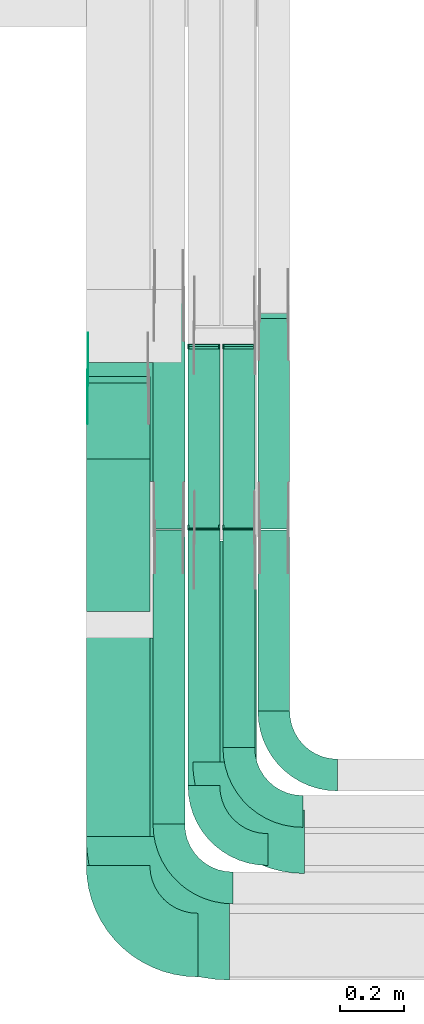
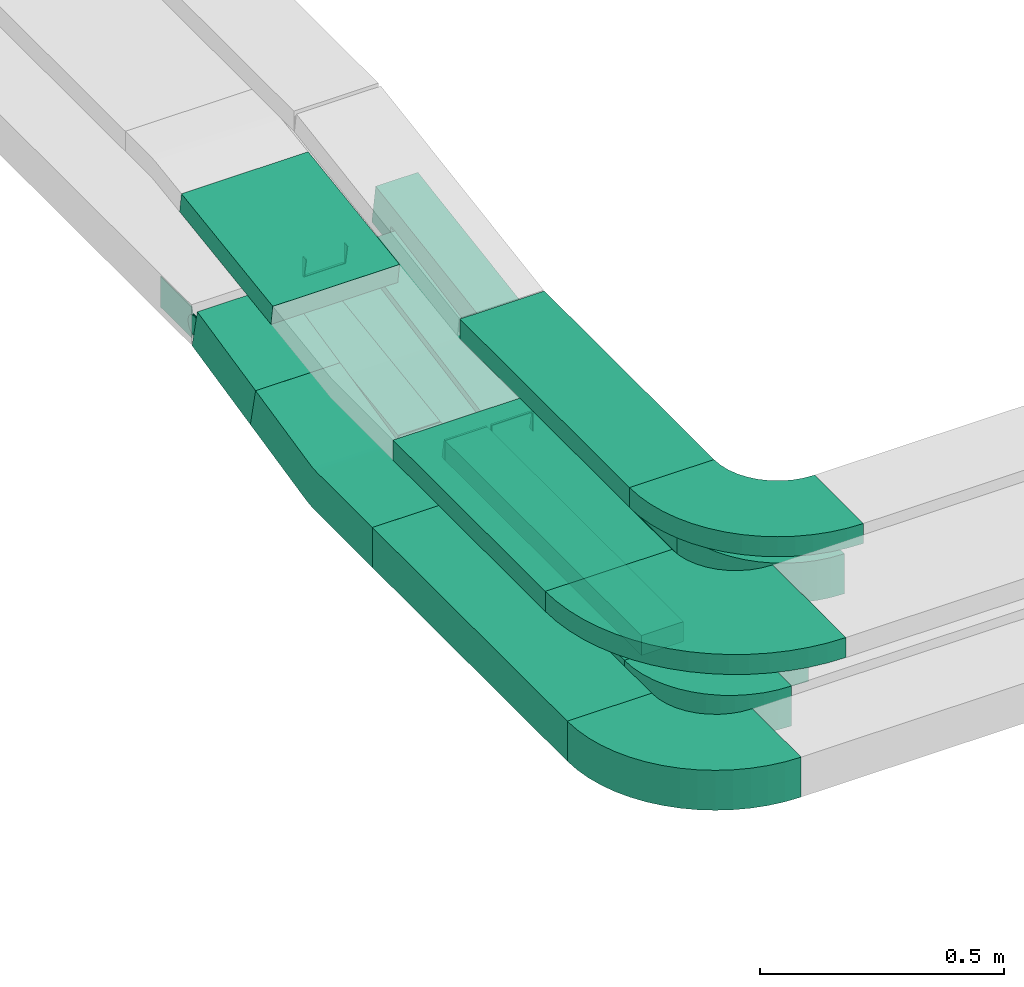
# One storey, part 4 of 31: 14 flow fittings, 13 flow segments.
"""IFC2X3 building model written with IfcOpenShell, lengths in millimetres."""

import ifcopenshell
import ifcopenshell.guid

model = None  # the IFC model being written
_history = None  # IfcOwnerHistory: only IFC2X3 demands one
_inside = {}  # id of a spatial element -> (the spatial element, [elements in it])
_under = {}  # id of a project, library or spatial element -> (it, [spatial elements below it])
_declared = {}  # id of a project -> (the project, [libraries it declares])
_typed = {}  # id of a type object -> (the type object, [elements of that type])
_made_of = {}  # id of a material, layer set ... -> (it, [elements and type objects made of it])


def new_model(schema):
    """Start an empty IFC model of exactly this schema.

    Asked for "IFC4X3", IfcOpenShell would pick the latest addendum, in which some entities
    have other attributes; the version numbers below select the first issue.
    IFC2X3 requires an IfcOwnerHistory on every rooted entity: one is made here for all.
    """
    global model, _history
    if schema == "IFC4X3":
        model = ifcopenshell.file(schema_version=(4, 3, 0, 0))
    else:
        model = ifcopenshell.file(schema=schema)
    _inside.clear()
    _under.clear()
    _declared.clear()
    _typed.clear()
    _made_of.clear()
    _history = None
    if model.schema == "IFC2X3":
        org = make("IfcOrganization", Name="unknown")
        user = make(
            "IfcPersonAndOrganization",
            ThePerson=make("IfcPerson", FamilyName="unknown"),
            TheOrganization=org,
        )
        app = make(
            "IfcApplication",
            ApplicationDeveloper=org,
            Version="unknown",
            ApplicationFullName="unknown",
            ApplicationIdentifier="unknown",
        )
        _history = make(
            "IfcOwnerHistory",
            OwningUser=user,
            OwningApplication=app,
            ChangeAction="ADDED",
            CreationDate=0,
        )
    return model


def make(cls, **values):
    """One entity of the class cls with the attributes given. An attribute that is None is left unset."""
    return model.create_entity(
        cls, **{name: value for name, value in values.items() if value is not None}
    )


def entity(cls, *values):
    """Any entity or typed value of the class cls, its attributes in the order of the schema. None: left unset."""
    e = model.create_entity(cls)
    for i, value in enumerate(values):
        if value is not None:
            e[i] = value
    return e


def rooted(cls, **values):
    """An entity with a GlobalId (a new one), such as an element, a storey or a relation."""
    return make(cls, GlobalId=ifcopenshell.guid.new(), OwnerHistory=_history, **values)


def si_unit(unit_type, name, prefix=None):
    """IfcSIUnit, for example si_unit("LENGTHUNIT", "METRE", prefix="MILLI")."""
    return make("IfcSIUnit", UnitType=unit_type, Prefix=prefix, Name=name)


def converted_unit(unit_type, name, factor, base, dimensions=None, offset=None):
    """IfcConversionBasedUnit, such as the inch: factor (a typed value) times the base unit."""
    return make(
        "IfcConversionBasedUnit"
        if offset is None
        else "IfcConversionBasedUnitWithOffset",
        ConversionOffset=offset,
        Dimensions=None
        if dimensions is None
        else entity("IfcDimensionalExponents", *dimensions),
        UnitType=unit_type,
        Name=name,
        ConversionFactor=make(
            "IfcMeasureWithUnit", ValueComponent=factor, UnitComponent=base
        ),
    )


def derived_unit(unit_type, elements):
    """IfcDerivedUnit: a product of units, each with its exponent."""
    return make(
        "IfcDerivedUnit",
        Elements=[
            make("IfcDerivedUnitElement", Unit=unit, Exponent=power)
            for unit, power in elements
        ],
        UnitType=unit_type,
    )


def assignment(units):
    """IfcUnitAssignment: the units of a project."""
    return None if units is None else make("IfcUnitAssignment", Units=units)


def point(xyz):
    """IfcCartesianPoint."""
    return None if xyz is None else make("IfcCartesianPoint", Coordinates=xyz)


def direction(xyz):
    """IfcDirection."""
    return None if xyz is None else make("IfcDirection", DirectionRatios=xyz)


def frame(location, z_axis=None, x_axis=None):
    """IfcAxis2Placement3D, a coordinate frame: its origin and axes. An axis left out is left unset."""
    return make(
        "IfcAxis2Placement3D",
        Location=point(location),
        Axis=direction(z_axis),
        RefDirection=direction(x_axis),
    )


def frame_2d(location, x_axis=None):
    """IfcAxis2Placement2D, a coordinate frame in the plane: its origin and x axis."""
    return make(
        "IfcAxis2Placement2D", Location=point(location), RefDirection=direction(x_axis)
    )


def origin():
    """The frame at (0, 0, 0) with its axes left unset."""
    return frame((0.0, 0.0, 0.0))


def origin_2d_with_axis():
    """The frame at (0, 0) in the plane with the x axis (1, 0) written out."""
    return frame_2d((0.0, 0.0), x_axis=(1.0, 0.0))


def place(relative_to, where):
    """IfcLocalPlacement: puts the frame where relative to a parent placement (None: the world)."""
    return make(
        "IfcLocalPlacement", PlacementRelTo=relative_to, RelativePlacement=where
    )


def context(
    kind, dimensions, precision=None, world=None, true_north=None, identifier=None
):
    """IfcGeometricRepresentationContext, for example the 3D "Model" context."""
    return make(
        "IfcGeometricRepresentationContext",
        ContextIdentifier=identifier,
        ContextType=kind,
        CoordinateSpaceDimension=dimensions,
        Precision=precision,
        WorldCoordinateSystem=world,
        TrueNorth=true_north,
    )


def subcontext(parent, identifier, kind, view, scale=None):
    """IfcGeometricRepresentationSubContext, for example "Body" below "Model"."""
    return make(
        "IfcGeometricRepresentationSubContext",
        ContextIdentifier=identifier,
        ContextType=kind,
        ParentContext=parent,
        TargetScale=scale,
        TargetView=view,
    )


def project(units=None, contexts=None):
    """IfcProject with its units and contexts."""
    return rooted(
        "IfcProject",
        Name="project",
        RepresentationContexts=contexts,
        UnitsInContext=assignment(units),
    )


def spatial(cls, under=None, at=None, **own):
    """A site, building, storey or space (cls), placed at a placement, below another one or the project."""
    s = rooted(cls, ObjectPlacement=at, **own)
    if under is not None:
        _under.setdefault(under.id(), (under, []))[1].append(s)
    return s


def polyline(points):
    """IfcPolyline through the points."""
    return make("IfcPolyline", Points=[point(p) for p in points])


def circle_curve(where, radius):
    """IfcCircle in the frame where."""
    return make("IfcCircle", Position=where, Radius=radius)


def parameter(value):
    """IfcParameterValue: where a trimmed curve begins or ends, as a parameter of its basis curve."""
    return model.create_entity("IfcParameterValue", value)


def trimmed(basis, trim1, trim2, sense, master):
    """IfcTrimmedCurve: the piece of a basis curve between two trims."""
    return make(
        "IfcTrimmedCurve",
        BasisCurve=basis,
        Trim1=trim1,
        Trim2=trim2,
        SenseAgreement=sense,
        MasterRepresentation=master,
    )


def segment(curve, same_sense, transition):
    """IfcCompositeCurveSegment."""
    return make(
        "IfcCompositeCurveSegment",
        Transition=transition,
        SameSense=same_sense,
        ParentCurve=curve,
    )


def composite_curve(segments, self_intersect=None):
    """IfcCompositeCurve: segments joined end to end."""
    return make("IfcCompositeCurve", Segments=segments, SelfIntersect=self_intersect)


def profile(cls, at=None, kind="AREA", **sizes):
    """A parametric profile (cls). Its sizes go by their IFC names, for example OverallWidth=200.0."""
    return make(cls, ProfileType=kind, Position=at, **sizes)


def rectangle(**sizes):
    """IfcRectangleProfileDef."""
    return profile("IfcRectangleProfileDef", **sizes)


def outline(outer, holes=None, kind="AREA"):
    """IfcArbitraryClosedProfileDef: a profile drawn as a closed curve; with holes, ...WithVoids."""
    if holes is None:
        return make("IfcArbitraryClosedProfileDef", ProfileType=kind, OuterCurve=outer)
    return make(
        "IfcArbitraryProfileDefWithVoids",
        ProfileType=kind,
        OuterCurve=outer,
        InnerCurves=holes,
    )


def extrude(swept, where, along, depth):
    """IfcExtrudedAreaSolid: the profile swept, set in the frame where, extruded along a direction by depth."""
    return make(
        "IfcExtrudedAreaSolid",
        SweptArea=swept,
        Position=where,
        ExtrudedDirection=direction(along),
        Depth=depth,
    )


def faces_of(points, faces, orient=None, outer=None):
    """IfcFace entities. A face is a list of loops; a loop is a list of indices into points, from 0.

    orient and outer hold one flag for each loop. By default every Orientation is true, the
    first loop of a face is its IfcFaceOuterBound and the others are IfcFaceBound.
    """
    made = []
    for i, loops in enumerate(faces):
        bounds = []
        for j, loop in enumerate(loops):
            is_outer = j == 0 if outer is None else outer[i][j]
            bounds.append(
                make(
                    "IfcFaceOuterBound" if is_outer else "IfcFaceBound",
                    Bound=make("IfcPolyLoop", Polygon=[points[k] for k in loop]),
                    Orientation=True if orient is None else orient[i][j],
                )
            )
        made.append(make("IfcFace", Bounds=bounds))
    return made


def faceted_brep(points, faces, orient=None, outer=None, voids=None):
    """IfcFacetedBrep: a solid bounded by flat faces; with voids (closed shells), ...WithVoids."""
    shared = [point(p) for p in points]
    hull = make("IfcClosedShell", CfsFaces=faces_of(shared, faces, orient, outer))
    if voids is None:
        return make("IfcFacetedBrep", Outer=hull)
    return make(
        "IfcFacetedBrepWithVoids",
        Outer=hull,
        Voids=[
            make(cls, CfsFaces=faces_of(shared, fs, o, b)) for cls, fs, o, b in voids
        ],
    )


def shape(context_of_items, identifier, shape_type, items):
    """IfcShapeRepresentation: the items that make up one representation, for example the "Body"."""
    return make(
        "IfcShapeRepresentation",
        ContextOfItems=context_of_items,
        RepresentationIdentifier=identifier,
        RepresentationType=shape_type,
        Items=items,
    )


def source(mapping_origin, context_of_items, identifier, shape_type, items):
    """IfcRepresentationMap: a shape defined once, which mapped items show again and again."""
    return make(
        "IfcRepresentationMap",
        MappingOrigin=mapping_origin,
        MappedRepresentation=shape(context_of_items, identifier, shape_type, items),
    )


def transform(
    local_origin,
    x_axis=None,
    y_axis=None,
    z_axis=None,
    scale=None,
    scale2=None,
    scale3=None,
    uniform=True,
):
    """IfcCartesianTransformationOperator3D, or its non-uniform kind. x_axis, y_axis, z_axis: its Axis1, 2, 3."""
    if uniform:
        return make(
            "IfcCartesianTransformationOperator3D",
            Axis1=direction(x_axis),
            Axis2=direction(y_axis),
            LocalOrigin=point(local_origin),
            Scale=scale,
            Axis3=direction(z_axis),
        )
    return make(
        "IfcCartesianTransformationOperator3DnonUniform",
        Axis1=direction(x_axis),
        Axis2=direction(y_axis),
        LocalOrigin=point(local_origin),
        Scale=scale,
        Axis3=direction(z_axis),
        Scale2=scale2,
        Scale3=scale3,
    )


def mapped(mapping_source, mapping_target):
    """IfcMappedItem: shows the shape of a source again, moved by a transform."""
    return make(
        "IfcMappedItem", MappingSource=mapping_source, MappingTarget=mapping_target
    )


def material(Name=None, Category=None):
    """IfcMaterial."""
    return make("IfcMaterial", Name=Name, Category=Category)


def made_of(thing, what):
    """Note that an element or type object is made of a material, layer set ...; save() writes the relation."""
    if what is not None:
        _made_of.setdefault(what.id(), (what, []))[1].append(thing)
    return thing


def type_object(cls, material=None, **own):
    """A type object (cls), such as IfcWallType, which elements share."""
    return made_of(rooted(cls, **own), material)


def type_shapes(of_type, sources):
    """Give a type object the sources (RepresentationMaps) that its elements show as mapped items."""
    of_type.RepresentationMaps = sources


def element(
    cls,
    number,
    at=None,
    inside=None,
    cuts=None,
    type_object=None,
    material=None,
    context=None,
    identifier="Body",
    shape_type=None,
    held_by="IfcProductDefinitionShape",
    body=None,
    shapes=None,
    **own,
):
    """One element of the class cls, such as IfcWall. Its Tag is "e" and its number.

    at: its placement. inside: the storey or other place that contains it. cuts: it is an
    opening in that element (IfcRelVoidsElement). A single representation is given by context,
    identifier, shape_type and body (its items); several are given by shapes. held_by: the class
    of the entity that holds the representations. save() writes the other relations.
    """
    e = rooted(cls, Tag="e%d" % number, ObjectPlacement=at, **own)
    if body is not None:
        shapes = [shape(context, identifier, shape_type, body)]
    if shapes is not None:
        e.Representation = make(held_by, Representations=shapes)
    if inside is not None:
        _inside.setdefault(inside.id(), (inside, []))[1].append(e)
    if cuts is not None:
        rooted(
            "IfcRelVoidsElement", RelatingBuildingElement=cuts, RelatedOpeningElement=e
        )
    if type_object is not None:
        _typed.setdefault(type_object.id(), (type_object, []))[1].append(e)
    return made_of(e, material)


def aggregate(whole, parts):
    """IfcRelAggregates: a whole, such as a stair, and the parts it consists of."""
    return rooted("IfcRelAggregates", RelatingObject=whole, RelatedObjects=parts)


def save(model, path):
    """Write the relations noted so far, then the file.

    IfcRelAggregates (storeys below a building ...), IfcRelContainedInSpatialStructure (elements
    in a storey), IfcRelDefinesByType, IfcRelAssociatesMaterial and IfcRelDeclares: one each for
    every whole, place, type object, material and project.
    """
    for whole, parts in _under.values():
        aggregate(whole, parts)
    for where, things in _inside.values():
        rooted(
            "IfcRelContainedInSpatialStructure",
            RelatedElements=things,
            RelatingStructure=where,
        )
    for kind, things in _typed.values():
        rooted("IfcRelDefinesByType", RelatedObjects=things, RelatingType=kind)
    for what, things in _made_of.values():
        rooted("IfcRelAssociatesMaterial", RelatedObjects=things, RelatingMaterial=what)
    for by, libraries in _declared.values():
        rooted("IfcRelDeclares", RelatingContext=by, RelatedDefinitions=libraries)
    model.write(path)


model = new_model("IFC2X3")

# Units and contexts
model_context = context("Model", 3, precision=0.01, world=origin(), true_north=direction((6.12303176911189e-17, 1.0)))
body_context = subcontext(model_context, "Body", "Model", "MODEL_VIEW")
ifc_project = project(units=[si_unit("LENGTHUNIT", "METRE", prefix="MILLI"), si_unit("AREAUNIT", "SQUARE_METRE"), si_unit("VOLUMEUNIT", "CUBIC_METRE"), converted_unit("PLANEANGLEUNIT", "DEGREE", entity("IfcRatioMeasure", 0.0174532925199433), si_unit("PLANEANGLEUNIT", "RADIAN"), dimensions=[0, 0, 0, 0, 0, 0, 0]), si_unit("MASSUNIT", "GRAM", prefix="KILO"), derived_unit("MASSDENSITYUNIT", [(si_unit("MASSUNIT", "GRAM", prefix="KILO"), 1), (si_unit("LENGTHUNIT", "METRE"), -3)]), derived_unit("MOMENTOFINERTIAUNIT", [(si_unit("LENGTHUNIT", "METRE"), 4)]), si_unit("TIMEUNIT", "SECOND"), si_unit("FREQUENCYUNIT", "HERTZ"), si_unit("THERMODYNAMICTEMPERATUREUNIT", "DEGREE_CELSIUS"), derived_unit("THERMALTRANSMITTANCEUNIT", [(si_unit("MASSUNIT", "GRAM", prefix="KILO"), 1), (si_unit("THERMODYNAMICTEMPERATUREUNIT", "KELVIN"), -1), (si_unit("TIMEUNIT", "SECOND"), -3)]), derived_unit("VOLUMETRICFLOWRATEUNIT", [(si_unit("LENGTHUNIT", "METRE"), 3), (si_unit("TIMEUNIT", "SECOND"), -1)]), derived_unit("MASSFLOWRATEUNIT", [(si_unit("MASSUNIT", "GRAM", prefix="KILO"), 1), (si_unit("TIMEUNIT", "SECOND"), -1)]), derived_unit("ROTATIONALFREQUENCYUNIT", [(si_unit("TIMEUNIT", "SECOND"), -1)]), si_unit("ELECTRICCURRENTUNIT", "AMPERE"), si_unit("ELECTRICVOLTAGEUNIT", "VOLT"), si_unit("POWERUNIT", "WATT"), si_unit("FORCEUNIT", "NEWTON", prefix="KILO"), si_unit("ILLUMINANCEUNIT", "LUX"), si_unit("LUMINOUSFLUXUNIT", "LUMEN"), si_unit("LUMINOUSINTENSITYUNIT", "CANDELA"), derived_unit("USERDEFINED", [(si_unit("MASSUNIT", "GRAM", prefix="KILO"), -1), (si_unit("LENGTHUNIT", "METRE"), -2), (si_unit("TIMEUNIT", "SECOND"), 3), (si_unit("LUMINOUSFLUXUNIT", "LUMEN"), 1)]), derived_unit("LINEARVELOCITYUNIT", [(si_unit("LENGTHUNIT", "METRE"), 1), (si_unit("TIMEUNIT", "SECOND"), -1)]), si_unit("PRESSUREUNIT", "PASCAL"), derived_unit("USERDEFINED", [(si_unit("LENGTHUNIT", "METRE"), -2), (si_unit("MASSUNIT", "GRAM", prefix="KILO"), 1), (si_unit("TIMEUNIT", "SECOND"), -2)]), derived_unit("LINEARFORCEUNIT", [(si_unit("MASSUNIT", "GRAM", prefix="KILO"), 1), (si_unit("LENGTHUNIT", "METRE"), 1), (si_unit("TIMEUNIT", "SECOND"), -2), (si_unit("LENGTHUNIT", "METRE"), -1)]), derived_unit("PLANARFORCEUNIT", [(si_unit("MASSUNIT", "GRAM", prefix="KILO"), 1), (si_unit("LENGTHUNIT", "METRE"), 1), (si_unit("TIMEUNIT", "SECOND"), -2), (si_unit("LENGTHUNIT", "METRE"), -2)])], contexts=[model_context])

# Site, building, storey
site_placement = place(None, frame((0.0, -0.00077364408347762, 0.0)))
site = spatial("IfcSite", under=ifc_project, at=site_placement, CompositionType="ELEMENT")
building_placement = place(site_placement, origin())
building = spatial("IfcBuilding", under=site, at=building_placement, CompositionType="ELEMENT")
storey_placement = place(building_placement, frame((0.0, 0.0, 15900.0)))
storey = spatial("IfcBuildingStorey", under=building, at=storey_placement, CompositionType="ELEMENT", Elevation=15900.0)

# Flow segments
cable_carrier_segment_type = type_object("IfcCableCarrierSegmentType", PredefinedType="CABLETRAYSEGMENT")
flow_segment_1_placement = place(storey_placement, frame((16533.5, 9853.44792892224, 2554.37042387779)))
element("IfcFlowSegment", 1, at=flow_segment_1_placement, inside=storey, type_object=cable_carrier_segment_type, context=body_context, shape_type="SweptSolid", body=[
    extrude(rectangle(XDim=100.000000000001, YDim=244.622531681312, at=frame_2d((1.05870867628255e-12, -2.27373675443232e-13), x_axis=(0.0, 1.0))), frame((0.0, 130.199518671403, 75.1209596823666), z_axis=(1.0, 0.0, 0.0), x_axis=(0.0, 0.976627229070763, 0.214940120586091)), (0.0, 0.0, 1.0), 200.0),
])
flow_segment_2_placement = place(storey_placement, frame((16743.5, 9633.37470982366, 2501.23724817348)))
element("IfcFlowSegment", 2, at=flow_segment_2_placement, inside=storey, type_object=cable_carrier_segment_type, context=body_context, shape_type="SweptSolid", body=[
    extrude(rectangle(XDim=100.000000000002, YDim=99.9999999999989, at=frame_2d((0.0, -7.8159700933611e-14), x_axis=(0.0, 1.0))), frame((50.0, 7.22885205823401, 49.4746773402338), z_axis=(0.0, 0.989493546804659, 0.144577041164689), x_axis=(-1.0, 0.0, 0.0)), (0.0, 0.0, 1.0), 732.026327691684),
])
flow_segment_3_placement = place(storey_placement, frame((16853.5, 9635.69171902177, 2501.27571553895)))
element("IfcFlowSegment", 3, at=flow_segment_3_placement, inside=storey, type_object=cable_carrier_segment_type, context=body_context, shape_type="SweptSolid", body=[
    extrude(rectangle(XDim=49.9999999999998, YDim=574.752456926632, at=frame_2d((5.40012479177676e-13, -9.76996261670138e-14), x_axis=(0.0, 1.0))), frame((0.0, 287.07950653115, 77.3533102309229), z_axis=(1.0, 0.0, 0.0), x_axis=(0.0, 0.982990459480717, 0.183656626806355)), (0.0, 0.0, 1.0), 99.9999999999989),
])
flow_segment_4_placement = place(storey_placement, frame((16963.5, 9635.69171902177, 2501.27571553895)))
element("IfcFlowSegment", 4, at=flow_segment_4_placement, inside=storey, type_object=cable_carrier_segment_type, context=body_context, shape_type="SweptSolid", body=[
    extrude(rectangle(XDim=49.9999999999998, YDim=574.752456926633, at=frame_2d((0.0, 0.0), x_axis=(0.0, 1.0))), frame((0.0, 287.07950653115, 77.3533102309229), z_axis=(1.0, 0.0, 0.0), x_axis=(0.0, 0.982990459480717, 0.183656626806355)), (0.0, 0.0, 1.0), 99.9999999999989),
])
flow_segment_5_placement = place(storey_placement, frame((17073.5, 9633.07792044488, 2501.44921481321)))
element("IfcFlowSegment", 5, at=flow_segment_5_placement, inside=storey, type_object=cable_carrier_segment_type, context=body_context, shape_type="SweptSolid", body=[
    extrude(rectangle(XDim=99.9999999999983, YDim=672.021585720091, at=frame_2d((1.08002495835535e-12, -1.74082970261225e-13), x_axis=(0.0, 1.0))), frame((0.0, 339.693305108029, 102.179810956662), z_axis=(1.0, 0.0, 0.0), x_axis=(0.0, 0.987576211285327, 0.157140786886536)), (0.0, 0.0, 1.0), 99.9999999999989),
])
flow_segment_6_placement = place(storey_placement, frame((16533.5, 8575.96624585794, 2500.0)))
element("IfcFlowSegment", 6, at=flow_segment_6_placement, inside=storey, type_object=cable_carrier_segment_type, context=body_context, shape_type="SweptSolid", body=[
    extrude(rectangle(XDim=798.975695122896, YDim=200.000000000002, at=frame_2d((5.40012479177676e-13, -2.16715534406831e-12), x_axis=(1.0, 0.0))), frame((100.0, 399.48784756145, 0.0), z_axis=(0.0, 0.0, 1.0), x_axis=(0.0, -1.0, 0.0)), (0.0, 0.0, 1.0), 99.9999999999989),
])
flow_segment_7_placement = place(storey_placement, frame((16743.5, 8705.96624585793, 2500.0)))
element("IfcFlowSegment", 7, at=flow_segment_7_placement, inside=storey, type_object=cable_carrier_segment_type, context=body_context, shape_type="SweptSolid", body=[
    extrude(rectangle(XDim=924.84066225427, YDim=99.9999999999989, at=origin_2d_with_axis()), frame((50.0, 462.420331127136, 0.0), z_axis=(0.0, 0.0, 1.0), x_axis=(0.0, -1.0, 0.0)), (0.0, 0.0, 1.0), 99.9999999999989),
])
flow_segment_8_placement = place(storey_placement, frame((16853.5, 8826.50215480077, 2500.0)))
element("IfcFlowSegment", 8, at=flow_segment_8_placement, inside=storey, type_object=cable_carrier_segment_type, context=body_context, shape_type="SweptSolid", body=[
    extrude(rectangle(XDim=804.598148550835, YDim=99.9999999999989, at=frame_2d((0.0, 1.08357767203415e-12), x_axis=(1.0, 0.0))), frame((50.0, 402.29907427542, 0.0), z_axis=(0.0, 0.0, 1.0), x_axis=(0.0, -1.0, 0.0)), (0.0, 0.0, 1.0), 50.0000000000016),
])
flow_segment_9_placement = place(storey_placement, frame((16963.5, 8946.50215480077, 2500.0)))
element("IfcFlowSegment", 9, at=flow_segment_9_placement, inside=storey, type_object=cable_carrier_segment_type, context=body_context, shape_type="SweptSolid", body=[
    extrude(rectangle(XDim=684.598148550835, YDim=99.9999999999989, at=frame_2d((5.40012479177676e-13, -1.08357767203415e-12), x_axis=(1.0, 0.0))), frame((50.0, 342.29907427542, 0.0), z_axis=(0.0, 0.0, 1.0), x_axis=(0.0, -1.0, 0.0)), (0.0, 0.0, 1.0), 49.9999999999995),
])
flow_segment_10_placement = place(storey_placement, frame((17073.5, 9060.96624585791, 2500.0)))
element("IfcFlowSegment", 10, at=flow_segment_10_placement, inside=storey, type_object=cable_carrier_segment_type, context=body_context, shape_type="SweptSolid", body=[
    extrude(rectangle(XDim=569.495535228138, YDim=99.9999999999989, at=frame_2d((5.40012479177676e-13, 1.08357767203415e-12), x_axis=(1.0, 0.0))), frame((50.0, 284.74776761407, 0.0), z_axis=(0.0, 0.0, 1.0), x_axis=(0.0, -1.0, 0.0)), (0.0, 0.0, 1.0), 99.9999999999989),
])
flow_segment_11_placement = place(storey_placement, frame((16868.4999999999, 8901.14880665489, 2820.0)))
element("IfcFlowSegment", 11, at=flow_segment_11_placement, inside=storey, type_object=cable_carrier_segment_type, context=body_context, shape_type="SweptSolid", body=[
    extrude(rectangle(XDim=695.282073093832, YDim=200.000000000002, at=frame_2d((0.0, 1.08713038571295e-12), x_axis=(1.0, 0.0))), frame((100.0, 347.641036546919, 0.0), z_axis=(0.0, 0.0, 1.0), x_axis=(0.0, 1.0, 0.0)), (0.0, 0.0, 1.0), 50.0000000000038),
])
flow_segment_12_placement = place(storey_placement, frame((16533.4999999999, 8666.1488066549, 2820.0)))
element("IfcFlowSegment", 12, at=flow_segment_12_placement, inside=storey, type_object=cable_carrier_segment_type, context=body_context, shape_type="SweptSolid", body=[
    extrude(rectangle(XDim=624.071371704514, YDim=300.000000000001, at=frame_2d((0.0, -1.08002495835535e-12), x_axis=(1.0, 0.0))), frame((150.0, 312.035685852259, 0.0), z_axis=(0.0, 0.0, 1.0), x_axis=(0.0, -1.0, 0.0)), (0.0, 0.0, 1.0), 50.0000000000016),
])
flow_segment_13_placement = place(storey_placement, frame((16533.4999999999, 9782.99132630117, 2856.33513699929)))
element("IfcFlowSegment", 13, at=flow_segment_13_placement, inside=storey, type_object=cable_carrier_segment_type, context=body_context, shape_type="SweptSolid", body=[
    extrude(rectangle(XDim=50.0000000000014, YDim=378.580677399284, at=frame_2d((3.26849658449646e-13, 2.1458390619955e-12), x_axis=(0.0, 1.0))), frame((0.0, 190.915994644883, 52.1043757603828), z_axis=(1.0, 0.0, 0.0), x_axis=(0.0, 0.98949354680465, 0.144577041164753)), (0.0, 0.0, 1.0), 299.999999999999),
])

# Flow fittings
ifc_material_1 = material()
cable_carrier_fitting_type_1 = type_object("IfcCableCarrierFittingType", Name="470_DKC_S5_Variable Angle Elbow 0-45:-", PredefinedType="NOTDEFINED", material=ifc_material_1)
shared_shape_1 = source(origin(), body_context, "Body", "SweptSolid", [
    extrude(outline(composite_curve([segment(polyline([(-100.749999999999, -150.250000000001), (-99.7499999999981, -150.250000000001)]), True, "CONTINUOUS"), segment(trimmed(circle_curve(frame_2d((-99.7500000000006, 99.7499999999987), x_axis=(0.0, -1.0)), 250.0), [parameter(0.0)], [parameter(90.0000000000001)], True, "PARAMETER"), True, "CONTINUOUS"), segment(polyline([(150.249999999999, 99.7500000000013), (150.249999999999, 100.750000000001)]), True, "CONTINUOUS"), segment(polyline([(150.249999999999, 100.750000000001), (50.2499999999992, 100.750000000001)]), True, "CONTINUOUS"), segment(polyline([(50.2499999999992, 100.750000000001), (50.2499999999992, 99.7500000000002)]), True, "CONTINUOUS"), segment(trimmed(circle_curve(frame_2d((-99.7500000000006, 99.7499999999987), x_axis=(0.0, -1.0)), 150.0), [parameter(0.0)], [parameter(90.0000000000001)], True, "PARAMETER"), False, "CONTINUOUS"), segment(polyline([(-99.7499999999989, -50.2500000000011), (-100.75, -50.2500000000011)]), True, "CONTINUOUS"), segment(polyline([(-100.75, -50.2500000000011), (-100.749999999999, -150.250000000001)]), True, "CONTINUOUS")], self_intersect=False)), frame((-100.249999999991, 100.249999999992, -50.0)), (0.0, 0.0, 1.0), 100.0),
])
type_shapes(cable_carrier_fitting_type_1, [shared_shape_1])
for number, where, z_axis, x_axis, name in (
    (14, (16793.5, 8504.96624585793, 2550.0), (0.0, 0.0, 1.0), (0.0, -1.0, 0.0), "470_DKC_S5_Variable Angle Elbow 0-45:-"),
    (15, (17123.5, 8859.96624585792, 2550.0), (0.0, 0.0, 1.0), (0.0, -1.0, 0.0), "470_DKC_S5_Variable Angle Elbow 0-45:-"),
):
    element("IfcFlowFitting", number, at=place(storey_placement, frame(where, z_axis=z_axis, x_axis=x_axis)), inside=storey, type_object=cable_carrier_fitting_type_1, material=ifc_material_1, Name=name, ObjectType="470_DKC_S5_Variable Angle Elbow 0-45:-", context=body_context, shape_type="MappedRepresentation", body=[
        mapped(shared_shape_1, transform((0.0, 0.0, 0.0), scale=1.0)),
    ])
cable_carrier_fitting_type_2 = type_object("IfcCableCarrierFittingType", Name="470_DKC_S5_Variable Angle Elbow 0-45:-", PredefinedType="NOTDEFINED", material=ifc_material_1)
shared_shape_2 = source(origin(), body_context, "Body", "SweptSolid", [
    extrude(outline(composite_curve([segment(polyline([(-100.750000000001, -150.25), (-99.7499999999994, -150.25)]), True, "CONTINUOUS"), segment(trimmed(circle_curve(frame_2d((-99.7499999999997, 99.7499999999995), x_axis=(0.0, -1.0)), 250.0), [parameter(0.0)], [parameter(90.0000000000001)], True, "PARAMETER"), True, "CONTINUOUS"), segment(polyline([(150.25, 99.75), (150.25, 100.749999999999)]), True, "CONTINUOUS"), segment(polyline([(150.25, 100.749999999999), (50.25, 100.75)]), True, "CONTINUOUS"), segment(polyline([(50.25, 100.75), (50.25, 99.7499999999998)]), True, "CONTINUOUS"), segment(trimmed(circle_curve(frame_2d((-99.7499999999997, 99.7499999999995), x_axis=(0.0, -1.0)), 150.0), [parameter(0.0)], [parameter(90.0000000000001)], True, "PARAMETER"), False, "CONTINUOUS"), segment(polyline([(-99.7499999999994, -50.2500000000003), (-100.750000000001, -50.2500000000003)]), True, "CONTINUOUS"), segment(polyline([(-100.750000000001, -50.2500000000003), (-100.750000000001, -150.25)]), True, "CONTINUOUS")], self_intersect=False)), frame((-100.249999999991, 100.249999999992, -25.0)), (0.0, 0.0, 1.0), 49.9999999999997),
])
type_shapes(cable_carrier_fitting_type_2, [shared_shape_2])
for number, where, z_axis, x_axis, name in (
    (16, (16903.5, 8625.50215480078, 2525.0), (0.0, 0.0, 1.0), (0.0, -1.0, 0.0), "470_DKC_S5_Variable Angle Elbow 0-45:-"),
    (17, (17013.5, 8745.50215480078, 2525.0), (0.0, 0.0, 1.0), (0.0, -1.0, 0.0), "470_DKC_S5_Variable Angle Elbow 0-45:-"),
):
    element("IfcFlowFitting", number, at=place(storey_placement, frame(where, z_axis=z_axis, x_axis=x_axis)), inside=storey, type_object=cable_carrier_fitting_type_2, material=ifc_material_1, Name=name, ObjectType="470_DKC_S5_Variable Angle Elbow 0-45:-", context=body_context, shape_type="MappedRepresentation", body=[
        mapped(shared_shape_2, transform((0.0, 0.0, 0.0), scale=1.0)),
    ])
cable_carrier_fitting_type_3 = type_object("IfcCableCarrierFittingType", Name="470_DKC_S5_Variable Angle Elbow 0-45:-", PredefinedType="NOTDEFINED", material=ifc_material_1)
shared_shape_3 = source(origin(), body_context, "Body", "SweptSolid", [
    extrude(outline(composite_curve([segment(polyline([(-125.750000000001, -225.25), (-124.749999999999, -225.25)]), True, "CONTINUOUS"), segment(trimmed(circle_curve(frame_2d((-124.75, 124.75), x_axis=(0.0, -1.0)), 350.0), [parameter(0.0)], [parameter(90.0000000000001)], True, "PARAMETER"), True, "CONTINUOUS"), segment(polyline([(225.25, 124.75), (225.25, 125.749999999999)]), True, "CONTINUOUS"), segment(polyline([(225.25, 125.749999999999), (25.25, 125.750000000001)]), True, "CONTINUOUS"), segment(polyline([(25.25, 125.750000000001), (25.25, 124.75)]), True, "CONTINUOUS"), segment(trimmed(circle_curve(frame_2d((-124.75, 124.75), x_axis=(0.0, -1.0)), 150.0), [parameter(0.0)], [parameter(90.0000000000001)], True, "PARAMETER"), False, "CONTINUOUS"), segment(polyline([(-124.749999999999, -25.2500000000003), (-125.750000000001, -25.2500000000003)]), True, "CONTINUOUS"), segment(polyline([(-125.750000000001, -25.2500000000003), (-125.750000000001, -225.25)]), True, "CONTINUOUS")], self_intersect=False)), frame((-125.249999999991, 125.249999999992, -50.0)), (0.0, 0.0, 1.0), 100.0),
])
type_shapes(cable_carrier_fitting_type_3, [shared_shape_3])
flow_fitting_1_placement = place(storey_placement, frame((16633.5, 8324.96624585795, 2550.0), z_axis=(0.0, 0.0, 1.0), x_axis=(0.0, -1.0, 0.0)))
element("IfcFlowFitting", 18, at=flow_fitting_1_placement, inside=storey, type_object=cable_carrier_fitting_type_3, material=ifc_material_1, Name="470_DKC_S5_Variable Angle Elbow 0-45:-", ObjectType="470_DKC_S5_Variable Angle Elbow 0-45:-", context=body_context, shape_type="MappedRepresentation", body=[
    mapped(shared_shape_3, transform((0.0, 0.0, 0.0), scale=1.0)),
])
cable_carrier_fitting_type_4 = type_object("IfcCableCarrierFittingType", Name="470_DKC_S5_Variable Angle Elbow 0-45:-", PredefinedType="NOTDEFINED", material=ifc_material_1)
shared_shape_4 = source(origin(), body_context, "Body", "SweptSolid", [
    extrude(outline(composite_curve([segment(polyline([(-150.749999999996, -300.250000000003), (-149.749999999994, -300.250000000003)]), True, "CONTINUOUS"), segment(trimmed(circle_curve(frame_2d((-149.750000000002, 149.749999999997), x_axis=(0.0, -1.0)), 450.0), [parameter(0.0)], [parameter(90.0000000000001)], True, "PARAMETER"), True, "CONTINUOUS"), segment(polyline([(300.249999999997, 149.750000000005), (300.249999999997, 150.750000000004)]), True, "CONTINUOUS"), segment(polyline([(300.249999999997, 150.750000000003), (0.249999999997449, 150.750000000002)]), True, "CONTINUOUS"), segment(polyline([(0.249999999997449, 150.750000000002), (0.249999999997438, 149.75)]), True, "CONTINUOUS"), segment(trimmed(circle_curve(frame_2d((-149.750000000002, 149.749999999997), x_axis=(0.0, -1.0)), 150.0), [parameter(0.0)], [parameter(90.0000000000001)], True, "PARAMETER"), False, "CONTINUOUS"), segment(polyline([(-149.749999999999, -0.250000000002818), (-150.750000000001, -0.250000000002835)]), True, "CONTINUOUS"), segment(polyline([(-150.750000000001, -0.250000000002835), (-150.749999999996, -300.250000000003)]), True, "CONTINUOUS")], self_intersect=False)), frame((-150.249999999991, 150.249999999992, -25.0)), (0.0, 0.0, 1.0), 49.9999999999974),
])
type_shapes(cable_carrier_fitting_type_4, [shared_shape_4])
flow_fitting_2_placement = place(storey_placement, frame((16683.4999999999, 8365.1488066549, 2845.0), z_axis=(0.0, 0.0, 1.0), x_axis=(0.0, -1.0, 0.0)))
element("IfcFlowFitting", 19, at=flow_fitting_2_placement, inside=storey, type_object=cable_carrier_fitting_type_4, material=ifc_material_1, Name="470_DKC_S5_Variable Angle Elbow 0-45:-", ObjectType="470_DKC_S5_Variable Angle Elbow 0-45:-", context=body_context, shape_type="MappedRepresentation", body=[
    mapped(shared_shape_4, transform((0.0, 0.0, 0.0), scale=1.0)),
])
cable_carrier_fitting_type_5 = type_object("IfcCableCarrierFittingType", Name="470_DKC_S5_Variable Angle Elbow 0-45:-", PredefinedType="NOTDEFINED", material=ifc_material_1)
shared_shape_5 = source(origin(), body_context, "Body", "SweptSolid", [
    extrude(outline(composite_curve([segment(polyline([(-125.750000000004, -225.249999999998), (-124.750000000003, -225.249999999998)]), True, "CONTINUOUS"), segment(trimmed(circle_curve(frame_2d((-124.749999999998, 124.750000000002), x_axis=(0.0, -1.0)), 350.0), [parameter(0.0)], [parameter(90.0)], True, "PARAMETER"), True, "CONTINUOUS"), segment(polyline([(225.250000000002, 124.749999999996), (225.250000000002, 125.749999999995)]), True, "CONTINUOUS"), segment(polyline([(225.250000000002, 125.749999999995), (25.2500000000021, 125.750000000001)]), True, "CONTINUOUS"), segment(polyline([(25.2500000000021, 125.750000000001), (25.2500000000021, 124.749999999999)]), True, "CONTINUOUS"), segment(trimmed(circle_curve(frame_2d((-124.749999999998, 124.750000000002), x_axis=(0.0, -1.0)), 150.0), [parameter(0.0)], [parameter(90.0)], True, "PARAMETER"), False, "CONTINUOUS"), segment(polyline([(-124.75, -25.2499999999979), (-125.750000000001, -25.2499999999979)]), True, "CONTINUOUS"), segment(polyline([(-125.750000000001, -25.2499999999979), (-125.750000000004, -225.249999999998)]), True, "CONTINUOUS")], self_intersect=False)), frame((-125.249999999991, 125.249999999992, -25.0)), (0.0, 0.0, 1.0), 50.000000000001),
])
type_shapes(cable_carrier_fitting_type_5, [shared_shape_5])
flow_fitting_3_placement = place(storey_placement, frame((16968.5, 8650.1488066549, 2845.0), z_axis=(0.0, 0.0, 1.0), x_axis=(0.0, -1.0, 0.0)))
element("IfcFlowFitting", 20, at=flow_fitting_3_placement, inside=storey, type_object=cable_carrier_fitting_type_5, material=ifc_material_1, Name="470_DKC_S5_Variable Angle Elbow 0-45:-", ObjectType="470_DKC_S5_Variable Angle Elbow 0-45:-", context=body_context, shape_type="MappedRepresentation", body=[
    mapped(shared_shape_5, transform((0.0, 0.0, 0.0), scale=1.0)),
])
ifc_material_2 = material(Name="G")
cable_carrier_fitting_type_6 = type_object("IfcCableCarrierFittingType", PredefinedType="NOTDEFINED", material=ifc_material_2)
shared_shape_6 = source(origin(), body_context, "Body", "SweptSolid", [
    extrude(outline(composite_curve([segment(trimmed(circle_curve(frame_2d((-41.4651162790697, 0.0), x_axis=(1.0, 0.0)), 25.0), [parameter(90.0000000000007)], [parameter(270.0)], True, "PARAMETER"), True, "CONTINUOUS"), segment(polyline([(-41.4651162790697, -25.0), (-29.9651162790697, -25.0)]), True, "CONTINUOUS"), segment(polyline([(-29.9651162790697, -25.0), (-28.1046511627907, -38.5)]), True, "CONTINUOUS"), segment(polyline([(-28.1046511627907, -38.5), (99.5348837209303, -38.5)]), True, "CONTINUOUS"), segment(polyline([(99.5348837209303, -38.5), (99.5348837209303, 38.5)]), True, "CONTINUOUS"), segment(polyline([(99.5348837209303, 38.5), (-28.1046511627907, 38.5)]), True, "CONTINUOUS"), segment(polyline([(-28.1046511627907, 38.5), (-29.9651162790697, 25.0)]), True, "CONTINUOUS"), segment(polyline([(-29.9651162790697, 25.0), (-41.46511627907, 25.0)]), True, "CONTINUOUS")], self_intersect=False)), frame((41.4651162790697, 0.0, 0.0)), (0.0, 0.0, 1.0), 2.0),
])
type_shapes(cable_carrier_fitting_type_6, [shared_shape_6])
flow_fitting_4_placement = place(storey_placement, frame((16538.0399999898, 10109.8113481977, 2657.25805153977), z_axis=(-1.0, 0.0, 0.0), x_axis=(0.0, -0.976627229070768, -0.214940120586069)))
element("IfcFlowFitting", 21, at=flow_fitting_4_placement, inside=storey, type_object=cable_carrier_fitting_type_6, material=ifc_material_2, context=body_context, shape_type="MappedRepresentation", body=[
    mapped(shared_shape_6, transform((0.0, 0.0, 0.0), scale=1.0)),
])
cable_carrier_fitting_type_7 = type_object("IfcCableCarrierFittingType", PredefinedType="NOTDEFINED", material=ifc_material_2)
shared_shape_7 = source(origin(), body_context, "Body", "SweptSolid", [
    extrude(outline(composite_curve([segment(trimmed(circle_curve(frame_2d((-41.4651162790697, 0.0), x_axis=(1.0, 0.0)), 25.0), [parameter(90.0000000000007)], [parameter(270.0)], True, "PARAMETER"), True, "CONTINUOUS"), segment(polyline([(-41.4651162790697, -25.0), (-29.9651162790697, -25.0)]), True, "CONTINUOUS"), segment(polyline([(-29.9651162790697, -25.0), (-28.1046511627907, -38.5)]), True, "CONTINUOUS"), segment(polyline([(-28.1046511627907, -38.5), (99.5348837209303, -38.5)]), True, "CONTINUOUS"), segment(polyline([(99.5348837209303, -38.5), (99.5348837209303, 38.5)]), True, "CONTINUOUS"), segment(polyline([(99.5348837209303, 38.5), (-28.1046511627907, 38.5)]), True, "CONTINUOUS"), segment(polyline([(-28.1046511627907, 38.5), (-29.9651162790697, 25.0)]), True, "CONTINUOUS"), segment(polyline([(-29.9651162790697, 25.0), (-41.46511627907, 25.0)]), True, "CONTINUOUS")], self_intersect=False)), frame((41.4651162790697, 0.0, 0.0), z_axis=(0.0, 0.0, -1.0), x_axis=(1.0, 0.0, 0.0)), (0.0, 0.0, -1.0), 2.0),
])
type_shapes(cable_carrier_fitting_type_7, [shared_shape_7])
flow_fitting_5_placement = place(storey_placement, frame((16540.0399999898, 10109.8113481976, 2657.25805153976), z_axis=(-1.0, 0.0, 0.0), x_axis=(0.0, 1.0, 0.0)))
element("IfcFlowFitting", 22, at=flow_fitting_5_placement, inside=storey, type_object=cable_carrier_fitting_type_7, material=ifc_material_2, context=body_context, shape_type="MappedRepresentation", body=[
    mapped(shared_shape_7, transform((0.0, 0.0, 0.0), scale=1.0)),
])
cable_carrier_fitting_type_8 = type_object("IfcCableCarrierFittingType", Name="470_DKC_S5_CS 90 internal vertical angle:-", PredefinedType="NOTDEFINED", material=ifc_material_1)
shared_shape_8 = source(origin(), body_context, "Body", "SweptSolid", [
    extrude(outline(composite_curve([segment(polyline([(-245.967958829446, -64.264573133663), (-16.3910981042456, -64.264573133663)]), True, "CONTINUOUS"), segment(trimmed(circle_curve(frame_2d((-16.3910981042459, 150.735426866336), x_axis=(0.0, -1.0)), 214.999999999999), [parameter(0.0)], [parameter(12.4120143362407)], True, "PARAMETER"), True, "CONTINUOUS"), segment(polyline([(29.82102782173, -59.2394273838844), (254.032041170554, -9.89414925586982)]), True, "CONTINUOUS"), segment(polyline([(254.032041170554, -9.89414925586986), (232.538029111961, 87.7685736512102)]), True, "CONTINUOUS"), segment(polyline([(232.538029111961, 87.7685736512102), (8.32701576313639, 38.4232955231956)]), True, "CONTINUOUS"), segment(trimmed(circle_curve(frame_2d((-16.3910981042459, 150.735426866336), x_axis=(0.0, -1.0)), 114.999999999999), [parameter(0.0)], [parameter(12.4120143362407)], True, "PARAMETER"), False, "CONTINUOUS"), segment(polyline([(-16.3910981042456, 35.7354268663373), (-245.967958829446, 35.7354268663373)]), True, "CONTINUOUS"), segment(polyline([(-245.967958829446, 35.7354268663373), (-245.967958829446, -64.264573133663)]), True, "CONTINUOUS")], self_intersect=False)), frame((-1.55114177541708, 14.2645731336556, -100.0)), (0.0, 0.0, 1.0), 200.0),
])
type_shapes(cable_carrier_fitting_type_8, [shared_shape_8])
flow_fitting_6_placement = place(storey_placement, frame((16633.5, 9622.4610415857, 2550.0), z_axis=(1.0, 0.0, 0.0), x_axis=(0.0, 1.0, 0.0)))
element("IfcFlowFitting", 23, at=flow_fitting_6_placement, inside=storey, type_object=cable_carrier_fitting_type_8, material=ifc_material_1, Name="470_DKC_S5_CS 90 internal vertical angle:-", ObjectType="470_DKC_S5_CS 90 internal vertical angle:-", context=body_context, shape_type="MappedRepresentation", body=[
    mapped(shared_shape_8, transform((0.0, 0.0, 0.0), scale=1.0)),
])
cable_carrier_fitting_type_9 = type_object("IfcCableCarrierFittingType", PredefinedType="NOTDEFINED", material=ifc_material_1)
shared_shape_9 = source(origin(), body_context, "Body", "Brep", [
    faceted_brep([(-4.63079955650548, 25.0, 50.0), (-4.63079955650548, 25.0, -50.0), (-4.63079955650564, -25.0, -50.0), (-4.63079955650564, -25.0, -47.4600000101565), (-4.63079955650549, 22.46000001016, -47.4600000101565), (-4.63079955650549, 22.46000001016, 47.4600000101635), (-4.63079955650564, -25.0, 47.4600000101635), (-4.63079955650564, -25.0, 50.0), (-0.0393838863460021, 25.4252385129817, 50.0), (9.1434474539729, -23.7242844610539, 50.0), (9.14344745397291, -23.7242844610539, 47.4600000101635), (0.42710394387625, 22.9284427558879, 47.4600000101635), (0.427103943876246, 22.9284427558879, -47.4600000101565), (9.1434474539729, -23.7242844610539, -47.4600000101565), (9.14344745397291, -23.7242844610539, -50.0), (-0.039383886346, 25.4252385129817, -50.0), (-2.31539977825246, 25.0, 50.0), (-2.3153997782525, 25.0, -50.0), (2.31539977825342, -25.0, -50.0), (2.31539977825342, -25.0, -47.4600000101565), (-2.08015516172298, 22.46000001016, -47.4600000101565), (-2.08015516172298, 22.46000001016, 47.4600000101635), (2.31539977825342, -25.0, 47.4600000101635), (2.31539977825342, -25.0, 50.0)], [[[0, 1, 2, 3, 4, 5, 6, 7]], [[8, 9, 10, 11, 12, 13, 14, 15]], [[1, 0, 16, 17]], [[2, 1, 17, 15, 14, 18]], [[3, 2, 18, 19]], [[4, 3, 19, 13, 12, 20]], [[5, 4, 20, 21]], [[6, 5, 21, 11, 10, 22]], [[7, 6, 22, 23]], [[0, 7, 23, 9, 8, 16]], [[17, 16, 8, 15]], [[19, 18, 14, 13]], [[21, 20, 12, 11]], [[23, 22, 10, 9]]]),
])
type_shapes(cable_carrier_fitting_type_9, [shared_shape_9])
for number, where, z_axis, x_axis in (
    (24, (16903.5, 9635.73110290811, 2525.0), (1.0, 0.0, 0.0), (0.0, 1.0, 0.0)),
    (25, (16903.5, 10209.8113481977, 2632.25805153974), (1.0, 0.0, 0.0), (0.0, -1.0, 0.0)),
    (26, (17013.5, 9635.73110290811, 2525.0), (1.0, 0.0, 0.0), (0.0, 1.0, 0.0)),
    (27, (17013.5, 10209.8113481977, 2632.25805153974), (1.0, 0.0, 0.0), (0.0, -1.0, 0.0)),
):
    element("IfcFlowFitting", number, at=place(storey_placement, frame(where, z_axis=z_axis, x_axis=x_axis)), inside=storey, type_object=cable_carrier_fitting_type_9, material=ifc_material_1, context=body_context, shape_type="MappedRepresentation", body=[
        mapped(shared_shape_9, transform((0.0, 0.0, 0.0), scale=1.0)),
    ])

save(model, "model.ifc")
